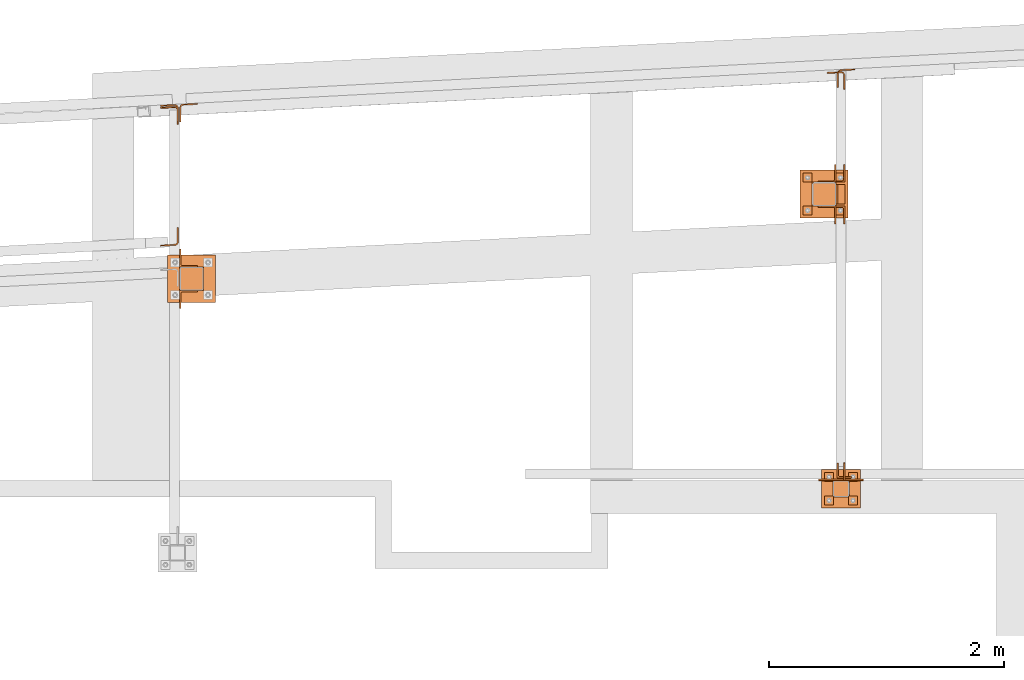
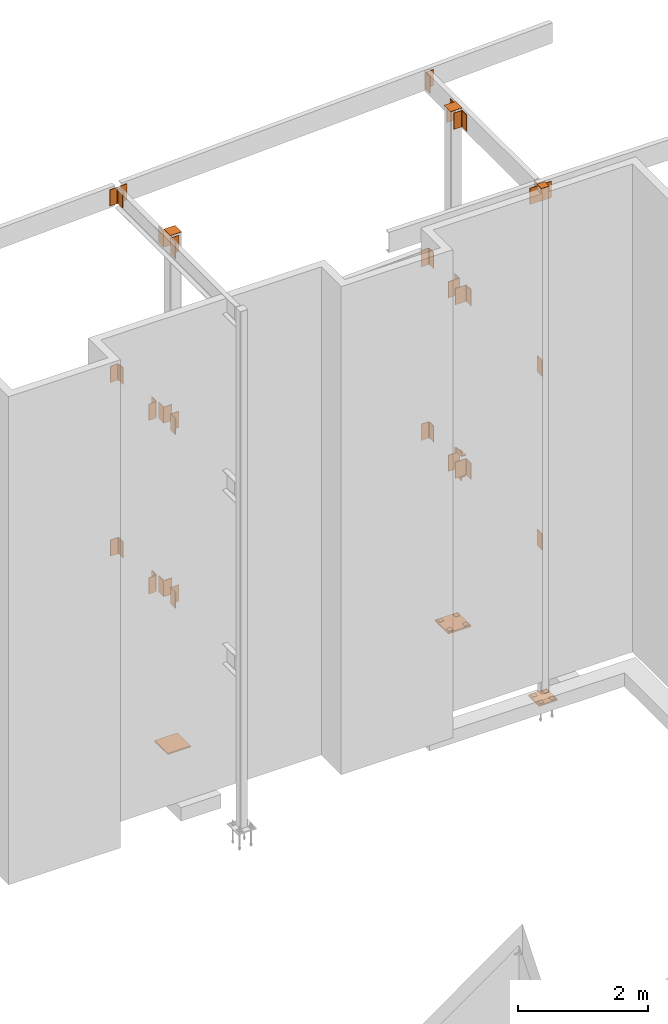
# One storey, part 10 of 89: 41 proxies.
"""IFC4 building model written with IfcOpenShell, lengths in feet."""

from ifc_helpers import new_model, entity, si_unit, converted_unit, derived_unit, direction, frame, origin, origin_2d_with_axis, place, context, subcontext, project, spatial, polyline, rectangle, outline, extrude, source, transform, mapped, material, type_object, type_shapes, element, save


model = new_model("IFC4")

# Units and contexts
model_context = context("Model", 3, precision=0.0001, world=origin(), true_north=direction((6.12303176911189e-17, 1.0)))
body_context = subcontext(model_context, "Body", "Model", "MODEL_VIEW")
ifc_project = project(units=[converted_unit("LENGTHUNIT", "FOOT", entity("IfcRatioMeasure", 0.3048), si_unit("LENGTHUNIT", "METRE"), dimensions=[1, 0, 0, 0, 0, 0, 0]), converted_unit("AREAUNIT", "SQUARE FOOT", entity("IfcRatioMeasure", 0.09290304), si_unit("AREAUNIT", "SQUARE_METRE"), dimensions=[2, 0, 0, 0, 0, 0, 0]), converted_unit("VOLUMEUNIT", "CUBIC FOOT", entity("IfcRatioMeasure", 0.028316846592), si_unit("VOLUMEUNIT", "CUBIC_METRE"), dimensions=[3, 0, 0, 0, 0, 0, 0]), si_unit("PLANEANGLEUNIT", "RADIAN"), si_unit("MASSUNIT", "GRAM", prefix="KILO"), derived_unit("MASSDENSITYUNIT", [(si_unit("MASSUNIT", "GRAM", prefix="KILO"), 1), (si_unit("LENGTHUNIT", "METRE"), -3)]), derived_unit("MOMENTOFINERTIAUNIT", [(si_unit("LENGTHUNIT", "METRE"), 4)]), si_unit("TIMEUNIT", "SECOND"), si_unit("FREQUENCYUNIT", "HERTZ"), si_unit("THERMODYNAMICTEMPERATUREUNIT", "DEGREE_CELSIUS"), derived_unit("THERMALTRANSMITTANCEUNIT", [(si_unit("MASSUNIT", "GRAM", prefix="KILO"), 1), (si_unit("THERMODYNAMICTEMPERATUREUNIT", "KELVIN"), -1), (si_unit("TIMEUNIT", "SECOND"), -3)]), derived_unit("VOLUMETRICFLOWRATEUNIT", [(si_unit("LENGTHUNIT", "METRE"), 3), (si_unit("TIMEUNIT", "SECOND"), -1)]), si_unit("ELECTRICCURRENTUNIT", "AMPERE"), si_unit("ELECTRICVOLTAGEUNIT", "VOLT"), si_unit("POWERUNIT", "WATT"), si_unit("FORCEUNIT", "NEWTON"), si_unit("ILLUMINANCEUNIT", "LUX"), si_unit("LUMINOUSFLUXUNIT", "LUMEN"), si_unit("LUMINOUSINTENSITYUNIT", "CANDELA"), derived_unit("USERDEFINED", [(si_unit("MASSUNIT", "GRAM", prefix="KILO"), -1), (si_unit("LENGTHUNIT", "METRE"), -2), (si_unit("TIMEUNIT", "SECOND"), 3), (si_unit("LUMINOUSFLUXUNIT", "LUMEN"), 1)]), derived_unit("LINEARVELOCITYUNIT", [(si_unit("LENGTHUNIT", "METRE"), 1), (si_unit("TIMEUNIT", "SECOND"), -1)]), si_unit("PRESSUREUNIT", "PASCAL"), derived_unit("USERDEFINED", [(si_unit("LENGTHUNIT", "METRE"), -2), (si_unit("MASSUNIT", "GRAM", prefix="KILO"), 1), (si_unit("TIMEUNIT", "SECOND"), -2)]), derived_unit("LINEARFORCEUNIT", [(si_unit("MASSUNIT", "GRAM", prefix="KILO"), 1), (si_unit("LENGTHUNIT", "METRE"), 1), (si_unit("TIMEUNIT", "SECOND"), -2), (si_unit("LENGTHUNIT", "METRE"), -1)]), derived_unit("PLANARFORCEUNIT", [(si_unit("MASSUNIT", "GRAM", prefix="KILO"), 1), (si_unit("LENGTHUNIT", "METRE"), 1), (si_unit("TIMEUNIT", "SECOND"), -2), (si_unit("LENGTHUNIT", "METRE"), -2)])], contexts=[model_context])

# Site, building, storey
site_placement = place(None, origin())
site = spatial("IfcSite", under=ifc_project, at=site_placement, CompositionType="ELEMENT")
building_placement = place(site_placement, frame((-472.238160486, -49.138065117, 0.0)))
building = spatial("IfcBuilding", under=site, at=building_placement, CompositionType="ELEMENT")
storey_placement = place(building_placement, origin())
storey = spatial("IfcBuildingStorey", under=building, at=storey_placement, Name="Level 1", CompositionType="ELEMENT", Elevation=0.0)

# Proxies
ifc_material_1 = material(Name="Color 7722", Category="Materials")
building_element_proxy_type_1 = type_object("IfcBuildingElementProxyType", Name="MATERIAL 9060:MATERIAL 9060", PredefinedType="NOTDEFINED", material=ifc_material_1)
shared_shape_1 = source(origin(), body_context, "Body", "SweptSolid", [
    extrude(rectangle(XDim=0.25, YDim=0.25, at=origin_2d_with_axis()), frame((0.125, -0.125, 0.0)), (0.0, 0.0, 1.0), 0.03125),
])
type_shapes(building_element_proxy_type_1, [shared_shape_1])
for number, where, z_axis, x_axis, name in (
    (1, (325.25, 1016.58333333333, -0.59375), (0.0, 0.0, -1.0), (0.0, -1.0, 0.0), "PW1"),
    (2, (326.166666666667, 1016.58333333333, -0.59375), (0.0, 0.0, -1.0), (0.0, -1.0, 0.0), "PW1"),
    (3, (326.166666666667, 1015.66666666667, -0.59375), (0.0, 0.0, -1.0), (0.0, -1.0, 0.0), "PW1"),
    (4, (325.848958333333, 1008.22916666667, -0.34375), (0.0, 0.0, -1.0), (0.0, -1.0, 0.0), "PW1"),
    (5, (326.515625, 1008.22916666667, -0.34375), (0.0, 0.0, -1.0), (0.0, -1.0, 0.0), "PW1"),
    (6, (326.515625, 1007.5625, -0.34375), (0.0, 0.0, -1.0), (0.0, -1.0, 0.0), "PW1"),
    (7, (325.848958333333, 1007.5625, -0.34375), (0.0, 0.0, -1.0), (0.0, -1.0, 0.0), "PW1"),
    (8, (325.25, 1015.66666666667, -0.59375), (0.0, 0.0, -1.0), (0.0, -1.0, 0.0), "PW1"),
):
    element("IfcBuildingElementProxy", number, at=place(building_placement, frame(where, z_axis=z_axis, x_axis=x_axis)), inside=storey, type_object=building_element_proxy_type_1, material=ifc_material_1, Name=name, ObjectType="MATERIAL", PredefinedType="NOTDEFINED", context=body_context, shape_type="MappedRepresentation", body=[
        mapped(shared_shape_1, transform((0.0, 0.0, 0.0), scale=1.0)),
    ])
ifc_material_2 = material(Name="Color 7718", Category="Materials")
building_element_proxy_type_2 = type_object("IfcBuildingElementProxyType", Name="MATERIAL 9158:MATERIAL 9158", PredefinedType="NOTDEFINED", material=ifc_material_2)
shared_shape_2 = source(origin(), body_context, "Body", "SweptSolid", [
    extrude(outline(polyline([(0.0111715792294897, -0.0976026118399068), (0.407378579745101, -0.0976026118399068), (0.407378579745101, -0.0611442785065728), (0.0111715792294897, -0.0611442785065728), (-0.00708529606607824, -0.0588217106174638), (-0.0241791222467533, -0.0520019654854818), (-0.0390209419147643, -0.0411194930595618), (-0.0506652611151263, -0.0268675581902408), (-0.0583702817624623, -0.0101540763871088), (-0.0616451576796762, 0.00795622468403817), (-0.0823810299218372, 0.403620237275397), (-0.118789398376419, 0.401712155537369), (-0.0980535261342592, 0.00604814294601114), (-0.0931412122585143, -0.0211173086606718), (-0.0815836812875102, -0.0461875313654078), (-0.0641172024869673, -0.0675654336693708), (-0.0418544729849502, -0.0838891423082878), (-0.0162137337138623, -0.0941187600062608), (0.0111715792294897, -0.0976026118399068)])), frame((0.0, -0.0926214202548993, -0.0976026118399068), z_axis=(1.0, 0.0, 0.0), x_axis=(0.0, -1.0, 0.0)), (0.0, 0.0, 1.0), 1.0),
])
type_shapes(building_element_proxy_type_2, [shared_shape_2])
for number, where, z_axis, x_axis, name in (
    (9, (307.803140822708, 1014.5705710156, 9.47916666666663), (0.0556972760760225, -0.998447701904167, 0.0), (0.0, 0.0, -1.0), "p56"),
    (10, (307.803341362608, 1014.57058220249, 20.1458333333333), (0.0556972760760225, -0.998447701904167, 0.0), (0.0, 0.0, -1.0), "p56"),
    (11, (307.833333333333, 1018.51190686592, 29.9583333333333), (-1.0, 0.0, 0.0), (0.0, 0.0, 1.0), "p59"),
    (12, (326.2, 1019.47467620937, 29.9583333333333), (-1.0, 0.0, 0.0), (0.0, 0.0, 1.0), "p59"),
):
    element("IfcBuildingElementProxy", number, at=place(building_placement, frame(where, z_axis=z_axis, x_axis=x_axis)), inside=storey, type_object=building_element_proxy_type_2, material=ifc_material_2, Name=name, ObjectType="MATERIAL", PredefinedType="NOTDEFINED", context=body_context, shape_type="MappedRepresentation", body=[
        mapped(shared_shape_2, transform((0.0, 0.0, 0.0), scale=1.0)),
    ])
building_element_proxy_type_3 = type_object("IfcBuildingElementProxyType", Name="MATERIAL 9508:MATERIAL 9508", PredefinedType="NOTDEFINED", material=ifc_material_2)
shared_shape_3 = source(origin(), body_context, "Body", "SweptSolid", [
    extrude(outline(polyline([(0.00933795100327561, -0.100513615372161), (0.394080749800685, -0.100513615372161), (0.394080749800685, -0.0640552820388279), (0.00933795100327567, -0.0640552820388279), (-0.0101481805857443, -0.0614033359186079), (-0.0282169086254994, -0.0536403977150289), (-0.0435539302164183, -0.0413311365164909), (-0.0550436443093494, -0.0253709168252909), (-0.0618502995158724, -0.0069206705551659), (-0.0634787859058903, 0.0126775481038942), (-0.0433429036232124, 0.396893070267087), (-0.0797512720777954, 0.398801152005115), (-0.0998871543604734, 0.0145856298419221), (-0.0974444247755213, -0.0148116981466309), (-0.0872344419656624, -0.0424870675518559), (-0.0699998708261134, -0.0664273970886559), (-0.0469943384400384, -0.0848912888864439), (-0.0198912463803294, -0.0965356961918699), (0.00933795100327561, -0.100513615372161)])), frame((0.0, 0.394080749800685, 0.398801152005115), z_axis=(1.0, 0.0, 0.0), x_axis=(0.0, -1.0, 0.0)), (0.0, 0.0, 1.0), 1.0),
])
type_shapes(building_element_proxy_type_3, [shared_shape_3])
for number, where, z_axis, x_axis, name in (
    (13, (307.300685232623, 1018.01190686592, 30.9583333333333), (1.0, 0.0, 0.0), (0.0, 0.0, -1.0), "p62"),
    (14, (307.300685232623, 1017.95824811843, 20.1458333333333), (1.0, 0.0, 0.0), (0.0, 0.0, -1.0), "p62"),
    (15, (325.91735189929, 1018.92826111025, 20.1458333333333), (1.0, 0.0, 0.0), (0.0, 0.0, -1.0), "p62"),
    (16, (307.300685232623, 1017.94848753585, 9.47916666666667), (1.0, 0.0, 0.0), (0.0, 0.0, -1.0), "p62"),
    (17, (325.91735189929, 1018.92610085713, 9.47916666666667), (1.0, 0.0, 0.0), (0.0, 0.0, -1.0), "p62"),
):
    element("IfcBuildingElementProxy", number, at=place(building_placement, frame(where, z_axis=z_axis, x_axis=x_axis)), inside=storey, type_object=building_element_proxy_type_3, material=ifc_material_2, Name=name, ObjectType="MATERIAL", PredefinedType="NOTDEFINED", context=body_context, shape_type="MappedRepresentation", body=[
        mapped(shared_shape_3, transform((0.0, 0.0, 0.0), scale=1.0)),
    ])
building_element_proxy_type_4 = type_object("IfcBuildingElementProxyType", Name="CONNECTION MATERIAL 9087:CONNECTION MATERIAL 9087", PredefinedType="NOTDEFINED", material=ifc_material_2)
shared_shape_4 = source(origin(), body_context, "Body", "SweptSolid", [
    extrude(rectangle(XDim=0.458333333333333, YDim=0.458333333333333, at=origin_2d_with_axis()), frame((0.0, 0.0, -0.0208333333333333)), (0.0, 0.0, 1.0), 0.0208333333333333),
])
type_shapes(building_element_proxy_type_4, [shared_shape_4])
proxy_1_placement = place(building_placement, frame((326.307291666667, 1007.77083333333, 31.0625), z_axis=(0.0, 0.0, -1.0), x_axis=(1.0, 0.0, 0.0)))
element("IfcBuildingElementProxy", 18, at=proxy_1_placement, inside=storey, type_object=building_element_proxy_type_4, material=ifc_material_2, Name="cp2", ObjectType="CONNECTION MATERIAL", PredefinedType="NOTDEFINED", context=body_context, shape_type="MappedRepresentation", body=[
    mapped(shared_shape_4, transform((0.0, 0.0, 0.0), scale=1.0)),
])
building_element_proxy_type_5 = type_object("IfcBuildingElementProxyType", Name="CONNECTION MATERIAL 9070:CONNECTION MATERIAL 9070", PredefinedType="NOTDEFINED", material=ifc_material_2)
shared_shape_5 = source(origin(), body_context, "Body", "SweptSolid", [
    extrude(rectangle(XDim=1.08333333333333, YDim=1.08333333333333, at=origin_2d_with_axis()), frame((0.0, 0.0, -0.0833333333333333)), (0.0, 0.0, 1.0), 0.0833333333333333),
])
type_shapes(building_element_proxy_type_5, [shared_shape_5])
proxy_2_placement = place(building_placement, frame((326.307291666667, 1007.77083333333, -0.375)))
element("IfcBuildingElementProxy", 19, at=proxy_2_placement, inside=storey, type_object=building_element_proxy_type_5, material=ifc_material_2, Name="bp1", ObjectType="CONNECTION MATERIAL", PredefinedType="NOTDEFINED", context=body_context, shape_type="MappedRepresentation", body=[
    mapped(shared_shape_5, transform((0.0, 0.0, 0.0), scale=1.0)),
])
ifc_material_3 = material(Name="Color", Category="Materials")
building_element_proxy_type_6 = type_object("IfcBuildingElementProxyType", Name="MATERIAL 9686:MATERIAL 9686", PredefinedType="NOTDEFINED", material=ifc_material_3)
shared_shape_6 = source(origin(), body_context, "Body", "SweptSolid", [
    extrude(outline(polyline([(-0.110359709391404, -0.306306957275258), (-0.0791097093914039, -0.306306957275258), (-0.0791097093914039, 0.0374430427247417), (-0.0759380232460259, 0.0533881857400047), (-0.0669058252741819, 0.0669058252741097), (-0.0533881857399629, 0.0759380232460297), (-0.0374430427247379, 0.0791097093914077), (0.306306957275262, 0.0791097093914077), (0.306306957275262, 0.110359709391408), (-0.110359709391404, 0.110359709391408), (-0.110359709391404, -0.306306957275258)])), frame((0.0, -0.110359709391404, 0.110359709391408), z_axis=(1.0, 0.0, 0.0), x_axis=(0.0, -1.0, 0.0)), (0.0, 0.0, 1.0), 1.0),
])
type_shapes(building_element_proxy_type_6, [shared_shape_6])
proxy_3_placement = place(building_placement, frame((326.2, 1008.075, 30.9583333333333), z_axis=(0.0, 1.0, 0.0), x_axis=(0.0, 0.0, -1.0)))
element("IfcBuildingElementProxy", 20, at=proxy_3_placement, inside=storey, type_object=building_element_proxy_type_6, material=ifc_material_3, Name="a12", ObjectType="MATERIAL", PredefinedType="NOTDEFINED", context=body_context, shape_type="MappedRepresentation", body=[
    mapped(shared_shape_6, transform((0.0, 0.0, 0.0), scale=1.0)),
])
building_element_proxy_type_7 = type_object("IfcBuildingElementProxyType", Name="MATERIAL:MATERIAL", PredefinedType="NOTDEFINED", material=ifc_material_2)
shared_shape_7 = source(origin(), body_context, "Body", "SweptSolid", [
    extrude(outline(polyline([(-0.130151376058071, -0.130151376058075), (0.369848623941929, -0.130151376058075), (0.369848623941929, -0.0936930427247416), (-0.0520263760580709, -0.0936930427247416), (-0.0679715190732959, -0.0905213565793626), (-0.0814891586075149, -0.0814891586074436), (-0.0905213565793589, -0.0679715190733376), (-0.0936930427247379, -0.0520263760580746), (-0.0936930427247379, 0.369848623941925), (-0.130151376058071, 0.369848623941925), (-0.130151376058071, -0.130151376058075)])), frame((0.0, -0.130151376058071, -0.130151376058075), z_axis=(1.0, 0.0, 0.0), x_axis=(0.0, -1.0, 0.0)), (0.0, 0.0, 1.0), 1.0),
])
type_shapes(building_element_proxy_type_7, [shared_shape_7])
for number, where, z_axis, x_axis, name in (
    (21, (307.833333333333, 1013.96875, 30.9583333333333), (-1.0, 0.0, 0.0), (0.0, 0.0, -1.0), "a15"),
    (22, (307.833333333333, 1013.30208333333, 30.9583333333333), (0.0, 1.0, 0.0), (0.0, 0.0, -1.0), "a15"),
    (23, (307.833333333333, 1013.96875, 20.1458333333333), (-1.0, 0.0, 0.0), (0.0, 0.0, -1.0), "a15"),
    (24, (307.833333333333, 1013.30208333333, 20.1458333333333), (0.0, 1.0, 0.0), (0.0, 0.0, -1.0), "a15"),
    (25, (307.833333333333, 1013.96875, 9.47916666666667), (-1.0, 0.0, 0.0), (0.0, 0.0, -1.0), "a15"),
    (26, (307.833333333333, 1013.30208333333, 9.47916666666667), (0.0, 1.0, 0.0), (0.0, 0.0, -1.0), "a15"),
    (27, (326.166666666667, 1015.66666666667, 30.9583333333333), (1.0, 0.0, 0.0), (0.0, 0.0, -1.0), "a15"),
    (28, (326.166666666667, 1016.33333333333, 30.9583333333333), (0.0, -1.0, 0.0), (0.0, 0.0, -1.0), "a15"),
):
    element("IfcBuildingElementProxy", number, at=place(building_placement, frame(where, z_axis=z_axis, x_axis=x_axis)), inside=storey, type_object=building_element_proxy_type_7, material=ifc_material_2, Name=name, ObjectType="MATERIAL", PredefinedType="NOTDEFINED", context=body_context, shape_type="MappedRepresentation", body=[
        mapped(shared_shape_7, transform((0.0, 0.0, 0.0), scale=1.0)),
    ])
building_element_proxy_type_8 = type_object("IfcBuildingElementProxyType", Name="MATERIAL 9134:MATERIAL 9134", PredefinedType="NOTDEFINED", material=ifc_material_3)
shared_shape_8 = source(origin(), body_context, "Body", "SweptSolid", [
    extrude(outline(polyline([(-0.0780822820435534, -0.0780822820435534), (0.171917717956447, -0.0780822820435534), (0.171917717956447, -0.04162394871022), (-0.01037394871022, -0.04162394871022), (-0.0223328059716291, -0.0392451841011977), (-0.0324710356222997, -0.0324710356222997), (-0.0392451841011977, -0.0223328059716291), (-0.04162394871022, -0.01037394871022), (-0.04162394871022, 0.171917717956447), (-0.0780822820435534, 0.171917717956447), (-0.0780822820435534, -0.0780822820435534)])), frame((0.0, -0.0780822820435534, -0.0780822820435534), z_axis=(1.0, 0.0, 0.0), x_axis=(0.0, -1.0, 0.0)), (0.0, 0.0, 1.0), 0.541666666666667),
])
type_shapes(building_element_proxy_type_8, [shared_shape_8])
for number, where, z_axis, x_axis, name in (
    (29, (326.166666666667, 1015.72916666667, 9.60416666666667), (-1.0, 0.0, 0.0), (0.0, 1.0, 0.0), "a4"),
    (30, (326.166666666667, 1015.72916666667, 8.35416666666667), (0.0, 0.0, 1.0), (0.0, 1.0, 0.0), "a4"),
):
    element("IfcBuildingElementProxy", number, at=place(building_placement, frame(where, z_axis=z_axis, x_axis=x_axis)), inside=storey, type_object=building_element_proxy_type_8, material=ifc_material_3, Name=name, ObjectType="MATERIAL", PredefinedType="NOTDEFINED", context=body_context, shape_type="MappedRepresentation", body=[
        mapped(shared_shape_8, transform((0.0, 0.0, 0.0), scale=1.0)),
    ])
building_element_proxy_type_9 = type_object("IfcBuildingElementProxyType", Name="CONNECTION MATERIAL 9054:CONNECTION MATERIAL 9054", PredefinedType="NOTDEFINED", material=ifc_material_2)
shared_shape_9 = source(origin(), body_context, "Body", "SweptSolid", [
    extrude(rectangle(XDim=0.666666666666667, YDim=0.666666666666667, at=origin_2d_with_axis()), frame((0.0, 0.0, -0.0208333333333333)), (0.0, 0.0, 1.0), 0.0208333333333333),
])
type_shapes(building_element_proxy_type_9, [shared_shape_9])
for number, where, z_axis, x_axis, name in (
    (31, (308.166666666667, 1013.63541666667, 31.0625), (0.0, 0.0, -1.0), (1.0, 0.0, 0.0), "cp1"),
    (32, (325.833333333333, 1016.0, 31.0625), (0.0, 0.0, -1.0), (1.0, 0.0, 0.0), "cp1"),
):
    element("IfcBuildingElementProxy", number, at=place(building_placement, frame(where, z_axis=z_axis, x_axis=x_axis)), inside=storey, type_object=building_element_proxy_type_9, material=ifc_material_2, Name=name, ObjectType="CONNECTION MATERIAL", PredefinedType="NOTDEFINED", context=body_context, shape_type="MappedRepresentation", body=[
        mapped(shared_shape_9, transform((0.0, 0.0, 0.0), scale=1.0)),
    ])
building_element_proxy_type_10 = type_object("IfcBuildingElementProxyType", Name="CONNECTION MATERIAL:CONNECTION MATERIAL", PredefinedType="NOTDEFINED", material=ifc_material_2)
shared_shape_10 = source(origin(), body_context, "Body", "SweptSolid", [
    extrude(rectangle(XDim=1.33333333333333, YDim=1.33333333333333, at=origin_2d_with_axis()), frame((0.0, 0.0, -0.0833333333333333)), (0.0, 0.0, 1.0), 0.0833333333333333),
])
type_shapes(building_element_proxy_type_10, [shared_shape_10])
for number, where, name in (
    (33, (308.166666666667, 1013.63541666667, -0.416666666666667), "bp2"),
    (34, (325.833333333333, 1016.0, -0.625), "bp2"),
):
    element("IfcBuildingElementProxy", number, at=place(building_placement, frame(where)), inside=storey, type_object=building_element_proxy_type_10, material=ifc_material_2, Name=name, ObjectType="CONNECTION MATERIAL", PredefinedType="NOTDEFINED", context=body_context, shape_type="MappedRepresentation", body=[
        mapped(shared_shape_10, transform((0.0, 0.0, 0.0), scale=1.0)),
    ])
building_element_proxy_type_11 = type_object("IfcBuildingElementProxyType", Name="MATERIAL 9063:MATERIAL 9063", PredefinedType="NOTDEFINED", material=ifc_material_3)
shared_shape_11 = source(origin(), body_context, "Body", "SweptSolid", [
    extrude(outline(polyline([(-0.163484709391404, -0.130151376058075), (0.503181957275262, -0.130151376058075), (0.503181957275262, -0.0936930427247416), (-0.0853597093914039, -0.0936930427247416), (-0.10130485240663, -0.0905213565793626), (-0.114822491940849, -0.0814891586074436), (-0.123854689912692, -0.0679715190733376), (-0.127026376058071, -0.0520263760580746), (-0.127026376058071, 0.369848623941925), (-0.163484709391404, 0.369848623941925), (-0.163484709391404, -0.130151376058075)])), frame((0.0, -0.163484709391404, -0.130151376058075), z_axis=(1.0, 0.0, 0.0), x_axis=(0.0, -1.0, 0.0)), (0.0, 0.0, 1.0), 1.0),
])
type_shapes(building_element_proxy_type_11, [shared_shape_11])
for number, where, z_axis, x_axis, name in (
    (35, (326.416666666667, 1016.33333333333, 20.1458333333333), (0.0, -1.0, 0.0), (0.0, 0.0, -1.0), "a14"),
    (36, (326.416666666667, 1015.66666666667, 19.1458333333333), (0.0, 1.0, 0.0), (0.0, 0.0, 1.0), "a14"),
    (37, (326.416666666667, 1016.33333333333, 9.47916666666667), (0.0, -1.0, 0.0), (0.0, 0.0, -1.0), "a14"),
    (38, (326.416666666667, 1015.66666666667, 8.47916666666667), (0.0, 1.0, 0.0), (0.0, 0.0, 1.0), "a14"),
):
    element("IfcBuildingElementProxy", number, at=place(building_placement, frame(where, z_axis=z_axis, x_axis=x_axis)), inside=storey, type_object=building_element_proxy_type_11, material=ifc_material_3, Name=name, ObjectType="MATERIAL", PredefinedType="NOTDEFINED", context=body_context, shape_type="MappedRepresentation", body=[
        mapped(shared_shape_11, transform((0.0, 0.0, 0.0), scale=1.0)),
    ])
building_element_proxy_type_12 = type_object("IfcBuildingElementProxyType", Name="MATERIAL 9080:MATERIAL 9080", PredefinedType="NOTDEFINED", material=ifc_material_3)
shared_shape_12 = source(origin(), body_context, "Body", "SweptSolid", [
    extrude(rectangle(XDim=1.25, YDim=1.0, at=origin_2d_with_axis()), frame((0.625, -0.5, 0.0)), (0.0, 0.0, 1.0), 0.0364583333333333),
])
type_shapes(building_element_proxy_type_12, [shared_shape_12])
proxy_4_placement = place(building_placement, frame((325.682291666667, 1008.03645833333, 30.9583333333333), z_axis=(0.0, -1.0, 0.0), x_axis=(1.0, 0.0, 0.0)))
element("IfcBuildingElementProxy", 39, at=proxy_4_placement, inside=storey, type_object=building_element_proxy_type_12, material=ifc_material_3, Name="p23", ObjectType="MATERIAL", PredefinedType="NOTDEFINED", context=body_context, shape_type="MappedRepresentation", body=[
    mapped(shared_shape_12, transform((0.0, 0.0, 0.0), scale=1.0)),
])
building_element_proxy_type_13 = type_object("IfcBuildingElementProxyType", Name="MATERIAL 9089:MATERIAL 9089", PredefinedType="NOTDEFINED", material=ifc_material_2)
shared_shape_13 = source(origin(), body_context, "Body", "SweptSolid", [
    extrude(rectangle(XDim=1.0, YDim=0.5, at=origin_2d_with_axis()), frame((0.5, -0.25, 0.0)), (0.0, 0.0, 1.0), 0.0364583333333333),
])
type_shapes(building_element_proxy_type_13, [shared_shape_13])
for number, where, z_axis, x_axis, name in (
    (40, (326.416666666667, 1008.0, 9.47916666666667), (-1.0, 0.0, 0.0), (0.0, 0.0, -1.0), "p21"),
    (41, (326.416666666667, 1008.0, 20.1458333333333), (-1.0, 0.0, 0.0), (0.0, 0.0, -1.0), "p21"),
):
    element("IfcBuildingElementProxy", number, at=place(building_placement, frame(where, z_axis=z_axis, x_axis=x_axis)), inside=storey, type_object=building_element_proxy_type_13, material=ifc_material_2, Name=name, ObjectType="MATERIAL", PredefinedType="NOTDEFINED", context=body_context, shape_type="MappedRepresentation", body=[
        mapped(shared_shape_13, transform((0.0, 0.0, 0.0), scale=1.0)),
    ])

save(model, "model.ifc")
